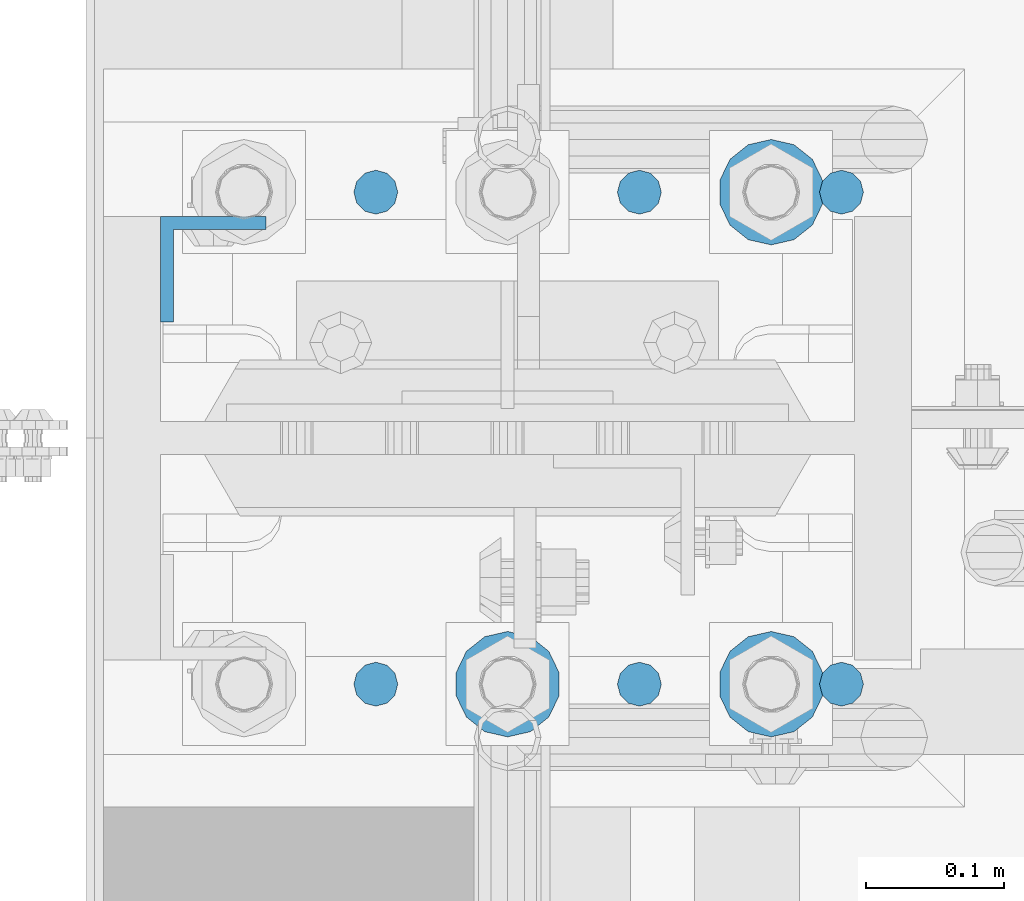
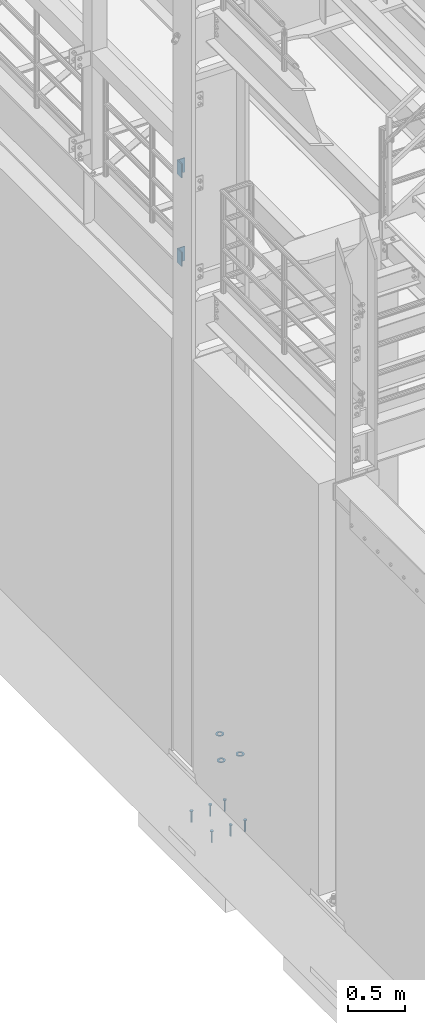
# One storey, part 816 of 1876: 11 columns, 2 elements without a shape of their own.
"""IFC2X3 building model written with IfcOpenShell, lengths in millimetres."""

from ifc_helpers import new_model, si_unit, frame, origin_with_axes, place, context, subcontext, project, spatial, faceted_brep, material, type_object, element, aggregate, save


model = new_model("IFC2X3")

# Units and contexts
model_context = context("Model", 3, precision=1e-05, world=origin_with_axes())
body_context = subcontext(model_context, "Body", "Model", "MODEL_VIEW")
ifc_project = project(units=[si_unit("LENGTHUNIT", "METRE", prefix="MILLI"), si_unit("AREAUNIT", "SQUARE_METRE"), si_unit("VOLUMEUNIT", "CUBIC_METRE"), si_unit("MASSUNIT", "GRAM", prefix="KILO"), si_unit("TIMEUNIT", "SECOND"), si_unit("PLANEANGLEUNIT", "RADIAN"), si_unit("SOLIDANGLEUNIT", "STERADIAN"), si_unit("THERMODYNAMICTEMPERATUREUNIT", "DEGREE_CELSIUS"), si_unit("LUMINOUSINTENSITYUNIT", "LUMEN")], contexts=[model_context])

# Site, building, storey
site_placement = place(None, origin_with_axes())
site = spatial("IfcSite", under=ifc_project, at=site_placement, CompositionType="ELEMENT")
building_placement = place(site_placement, origin_with_axes())
building = spatial("IfcBuilding", under=site, at=building_placement, Name="Undefined", CompositionType="ELEMENT")
storey_placement = place(building_placement, origin_with_axes())
storey = spatial("IfcBuildingStorey", under=building, at=storey_placement, Name="Undefined", CompositionType="ELEMENT", Elevation=0.0)

# Assembly, columns
assembly_1_placement = place(storey_placement, origin_with_axes())
assembly_1 = element("IfcElementAssembly", 1, at=assembly_1_placement, inside=storey, Name="COLUMN", AssemblyPlace="NOTDEFINED", PredefinedType="RIGID_FRAME")
ifc_material_1 = material(Name="STEEL/A36")
column_type_1 = type_object("IfcColumnType", Name="L3X3X3/8", PredefinedType="NOTDEFINED")
column_1_placement = place(assembly_1_placement, frame((-212.725, -4449.7625, 6254.75), z_axis=(0.0, -1.0, 0.0), x_axis=(0.0, 0.0, 1.0)))
column_1 = element("IfcColumn", 2, at=column_1_placement, type_object=column_type_1, material=ifc_material_1, Name="ANGLE", ObjectType="L3X3X3/8", context=body_context, shape_type="Brep", body=[
    faceted_brep([(0.0, 38.1000000000004, -38.1), (0.0, 38.1000000000004, 38.1), (152.4, 38.1000000000004, 38.1), (152.4, 38.1000000000004, -38.1), (0.0, 28.5749999999998, 38.1), (152.4, 28.5749999999998, 38.1), (0.0, 28.5749999999998, -28.575), (152.4, 28.5749999999998, -28.575), (0.0, -38.1000000000004, -28.575), (152.4, -38.1000000000004, -28.575), (0.0, -38.1000000000004, -38.1), (152.4, -38.1000000000004, -38.1)], [[[0, 1, 2, 3]], [[1, 4, 5, 2]], [[4, 6, 7, 5]], [[6, 8, 9, 7]], [[8, 10, 11, 9]], [[10, 0, 3, 11]], [[5, 7, 9, 11, 3, 2]], [[10, 8, 6, 4, 1, 0]]]),
])
column_2_placement = place(assembly_1_placement, frame((-212.725, -4449.7625, 5308.6), z_axis=(0.0, -1.0, 0.0), x_axis=(0.0, 0.0, 1.0)))
column_2 = element("IfcColumn", 3, at=column_2_placement, type_object=column_type_1, material=ifc_material_1, Name="ANGLE", ObjectType="L3X3X3/8", context=body_context, shape_type="Brep", body=[
    faceted_brep([(0.0, 38.1000000000004, -38.1), (0.0, 38.1000000000004, 38.1), (152.4, 38.1000000000004, 38.1), (152.4, 38.1000000000004, -38.1), (0.0, 28.5749999999998, 38.1), (152.4, 28.5749999999998, 38.1), (0.0, 28.5749999999998, -28.575), (152.4, 28.5749999999998, -28.575), (0.0, -38.1000000000004, -28.575), (152.4, -38.1000000000004, -28.575), (0.0, -38.1000000000004, -38.1), (152.4, -38.1000000000004, -38.1)], [[[0, 1, 2, 3]], [[1, 4, 5, 2]], [[4, 6, 7, 5]], [[6, 8, 9, 7]], [[8, 10, 11, 9]], [[10, 0, 3, 11]], [[5, 7, 9, 11, 3, 2]], [[10, 8, 6, 4, 1, 0]]]),
])
aggregate(assembly_1, [column_1, column_2])

assembly_2_placement = place(storey_placement, origin_with_axes())
assembly_2 = element("IfcElementAssembly", 4, at=assembly_2_placement, inside=storey, Name="TEMPLATE", AssemblyPlace="NOTDEFINED", PredefinedType="RIGID_FRAME")
ifc_material_2 = material(Name="STEEL/F436")
column_type_2 = type_object("IfcColumnType", Name="1-1/2_WASHER", PredefinedType="NOTDEFINED")
column_3_placement = place(assembly_2_placement, frame((190.5, -4749.8, 109.5375), z_axis=(1.0, 0.0, 0.0), x_axis=(0.0, 0.0, -1.0)))
column_3 = element("IfcColumn", 5, at=column_3_placement, type_object=column_type_2, material=ifc_material_2, Name="WASHER", ObjectType="1-1/2_WASHER", context=body_context, shape_type="Brep", body=[
    faceted_brep([(0.0, -38.0999984741211, 0.0), (0.0, -34.3269124923136, -16.5309697983251), (4.7625, -34.3269124923136, -16.5309697983251), (4.7625, -38.0999984741211, 0.0), (0.0, -23.7549604994474, -29.787778289052), (4.7625, -23.7549604994474, -29.787778289052), (0.0, -8.4780472441962, -37.1447519665058), (4.7625, -8.4780472441962, -37.1447519665058), (0.0, 8.4780472441962, -37.1447519665058), (4.7625, 8.4780472441962, -37.1447519665058), (0.0, 23.7549604994474, -29.787778289052), (4.7625, 23.7549604994474, -29.787778289052), (0.0, 34.3269124923136, -16.5309697983251), (4.7625, 34.3269124923136, -16.5309697983251), (0.0, 38.0999984741211, 0.0), (4.7625, 38.0999984741211, 0.0), (0.0, 34.3269124923136, 16.5309697983251), (4.7625, 34.3269124923136, 16.5309697983251), (0.0, 23.7549604994474, 29.787778289052), (4.7625, 23.7549604994474, 29.787778289052), (0.0, 8.4780472441962, 37.1447519665058), (4.7625, 8.4780472441962, 37.1447519665058), (0.0, -8.4780472441962, 37.1447519665058), (4.7625, -8.4780472441962, 37.1447519665058), (0.0, -23.7549604994474, 29.787778289052), (4.7625, -23.7549604994474, 29.787778289052), (0.0, -34.3269124923136, 16.5309697983251), (4.7625, -34.3269124923136, 16.5309697983251), (0.0, 0.0, 20.6399993896484), (0.0, 8.95536011056538, 18.5959968835978), (4.7625, 8.95536011056538, 18.595996883598), (4.7625, 0.0, 20.6399993896484), (0.0, 16.1370013209489, 12.8688291298158), (4.7625, 16.1370013209489, 12.8688291298162), (0.0, 20.1225115123834, 4.59283194104228), (4.7625, 20.1225115123834, 4.59283194104222), (0.0, 20.1225115123834, -4.59283194104228), (4.7625, 20.1225115123834, -4.59283194104242), (0.0, 16.1370013209489, -12.8688291298167), (4.7625, 16.1370013209489, -12.8688291298163), (0.0, 8.95536011056538, -18.5959968835978), (4.7625, 8.95536011056538, -18.5959968835982), (0.0, 0.0, -20.6399993896484), (4.7625, 0.0, -20.6399993896484), (0.0, -8.95536011056538, -18.5959968835978), (4.7625, -8.95536011056538, -18.595996883598), (0.0, -16.1370013209489, -12.8688291298158), (4.7625, -16.1370013209489, -12.8688291298162), (0.0, -20.1225115123834, -4.59283194104228), (4.7625, -20.1225115123834, -4.59283194104222), (0.0, -20.1225115123834, 4.59283194104228), (4.7625, -20.1225115123834, 4.59283194104242), (0.0, -16.1370013209489, 12.8688291298167), (4.7625, -16.1370013209489, 12.8688291298163), (0.0, -8.95536011056538, 18.5959968835978), (4.7625, -8.95536011056538, 18.5959968835982)], [[[0, 1, 2, 3]], [[1, 4, 5, 2]], [[4, 6, 7, 5]], [[6, 8, 9, 7]], [[8, 10, 11, 9]], [[10, 12, 13, 11]], [[12, 14, 15, 13]], [[14, 16, 17, 15]], [[16, 18, 19, 17]], [[18, 20, 21, 19]], [[20, 22, 23, 21]], [[22, 24, 25, 23]], [[24, 26, 27, 25]], [[26, 0, 3, 27]], [[28, 29, 30, 31]], [[29, 32, 33, 30]], [[32, 34, 35, 33]], [[34, 36, 37, 35]], [[36, 38, 39, 37]], [[38, 40, 41, 39]], [[40, 42, 43, 41]], [[42, 44, 45, 43]], [[44, 46, 47, 45]], [[46, 48, 49, 47]], [[48, 50, 51, 49]], [[50, 52, 53, 51]], [[52, 54, 55, 53]], [[54, 28, 31, 55]], [[5, 7, 9, 11, 13, 15, 17, 19, 21, 23, 25, 27, 3, 2], [33, 35, 37, 39, 41, 43, 45, 47, 49, 51, 53, 55, 31, 30]], [[26, 24, 22, 20, 18, 16, 14, 12, 10, 8, 6, 4, 1, 0], [54, 52, 50, 48, 46, 44, 42, 40, 38, 36, 34, 32, 29, 28]]]),
])
column_4_placement = place(assembly_2_placement, frame((190.5, -4394.2, 109.5375), z_axis=(-1.0, 0.0, 0.0), x_axis=(0.0, 0.0, -1.0)))
column_4 = element("IfcColumn", 6, at=column_4_placement, type_object=column_type_2, material=ifc_material_2, Name="WASHER", ObjectType="1-1/2_WASHER", context=body_context, shape_type="Brep", body=[
    faceted_brep([(0.0, -38.0999984741211, 0.0), (0.0, -34.3269124923136, -16.5309697983251), (4.7625, -34.3269124923136, -16.5309697983251), (4.7625, -38.0999984741211, 0.0), (0.0, -23.7549604994474, -29.787778289052), (4.7625, -23.7549604994474, -29.787778289052), (0.0, -8.4780472441962, -37.1447519665058), (4.7625, -8.4780472441962, -37.1447519665058), (0.0, 8.4780472441962, -37.1447519665058), (4.7625, 8.4780472441962, -37.1447519665058), (0.0, 23.7549604994474, -29.787778289052), (4.7625, 23.7549604994474, -29.787778289052), (0.0, 34.3269124923136, -16.5309697983251), (4.7625, 34.3269124923136, -16.5309697983251), (0.0, 38.0999984741211, 0.0), (4.7625, 38.0999984741211, 0.0), (0.0, 34.3269124923136, 16.5309697983251), (4.7625, 34.3269124923136, 16.5309697983251), (0.0, 23.7549604994474, 29.787778289052), (4.7625, 23.7549604994474, 29.787778289052), (0.0, 8.4780472441962, 37.1447519665058), (4.7625, 8.4780472441962, 37.1447519665058), (0.0, -8.4780472441962, 37.1447519665058), (4.7625, -8.4780472441962, 37.1447519665058), (0.0, -23.7549604994474, 29.787778289052), (4.7625, -23.7549604994474, 29.787778289052), (0.0, -34.3269124923136, 16.5309697983251), (4.7625, -34.3269124923136, 16.5309697983251), (0.0, 0.0, 20.6399993896484), (0.0, 8.95536011056538, 18.5959968835978), (4.7625, 8.95536011056538, 18.595996883598), (4.7625, 0.0, 20.6399993896484), (0.0, 16.1370013209489, 12.8688291298158), (4.7625, 16.1370013209489, 12.8688291298162), (0.0, 20.1225115123834, 4.59283194104228), (4.7625, 20.1225115123834, 4.59283194104222), (0.0, 20.1225115123834, -4.59283194104228), (4.7625, 20.1225115123834, -4.59283194104242), (0.0, 16.1370013209489, -12.8688291298167), (4.7625, 16.1370013209489, -12.8688291298163), (0.0, 8.95536011056538, -18.5959968835978), (4.7625, 8.95536011056538, -18.5959968835982), (0.0, 0.0, -20.6399993896484), (4.7625, 0.0, -20.6399993896484), (0.0, -8.95536011056538, -18.5959968835978), (4.7625, -8.95536011056538, -18.595996883598), (0.0, -16.1370013209489, -12.8688291298158), (4.7625, -16.1370013209489, -12.8688291298162), (0.0, -20.1225115123834, -4.59283194104228), (4.7625, -20.1225115123834, -4.59283194104222), (0.0, -20.1225115123834, 4.59283194104228), (4.7625, -20.1225115123834, 4.59283194104242), (0.0, -16.1370013209489, 12.8688291298167), (4.7625, -16.1370013209489, 12.8688291298163), (0.0, -8.95536011056538, 18.5959968835978), (4.7625, -8.95536011056538, 18.5959968835982)], [[[0, 1, 2, 3]], [[1, 4, 5, 2]], [[4, 6, 7, 5]], [[6, 8, 9, 7]], [[8, 10, 11, 9]], [[10, 12, 13, 11]], [[12, 14, 15, 13]], [[14, 16, 17, 15]], [[16, 18, 19, 17]], [[18, 20, 21, 19]], [[20, 22, 23, 21]], [[22, 24, 25, 23]], [[24, 26, 27, 25]], [[26, 0, 3, 27]], [[28, 29, 30, 31]], [[29, 32, 33, 30]], [[32, 34, 35, 33]], [[34, 36, 37, 35]], [[36, 38, 39, 37]], [[38, 40, 41, 39]], [[40, 42, 43, 41]], [[42, 44, 45, 43]], [[44, 46, 47, 45]], [[46, 48, 49, 47]], [[48, 50, 51, 49]], [[50, 52, 53, 51]], [[52, 54, 55, 53]], [[54, 28, 31, 55]], [[5, 7, 9, 11, 13, 15, 17, 19, 21, 23, 25, 27, 3, 2], [33, 35, 37, 39, 41, 43, 45, 47, 49, 51, 53, 55, 31, 30]], [[26, 24, 22, 20, 18, 16, 14, 12, 10, 8, 6, 4, 1, 0], [54, 52, 50, 48, 46, 44, 42, 40, 38, 36, 34, 32, 29, 28]]]),
])
column_5_placement = place(assembly_2_placement, frame((-2.8421709430404e-14, -4749.8, 109.5375), z_axis=(1.0, 0.0, 0.0), x_axis=(0.0, 0.0, -1.0)))
column_5 = element("IfcColumn", 7, at=column_5_placement, type_object=column_type_2, material=ifc_material_2, Name="WASHER", ObjectType="1-1/2_WASHER", context=body_context, shape_type="Brep", body=[
    faceted_brep([(0.0, -38.0999984741211, 0.0), (0.0, -34.3269124923136, -16.5309697983251), (4.7625, -34.3269124923136, -16.5309697983251), (4.7625, -38.0999984741211, 0.0), (0.0, -23.7549604994474, -29.787778289052), (4.7625, -23.7549604994474, -29.787778289052), (0.0, -8.4780472441962, -37.1447519665058), (4.7625, -8.4780472441962, -37.1447519665058), (0.0, 8.4780472441962, -37.1447519665058), (4.7625, 8.4780472441962, -37.1447519665058), (0.0, 23.7549604994474, -29.787778289052), (4.7625, 23.7549604994474, -29.787778289052), (0.0, 34.3269124923136, -16.5309697983251), (4.7625, 34.3269124923136, -16.5309697983251), (0.0, 38.0999984741211, 0.0), (4.7625, 38.0999984741211, 0.0), (0.0, 34.3269124923136, 16.5309697983251), (4.7625, 34.3269124923136, 16.5309697983251), (0.0, 23.7549604994474, 29.787778289052), (4.7625, 23.7549604994474, 29.787778289052), (0.0, 8.4780472441962, 37.1447519665058), (4.7625, 8.4780472441962, 37.1447519665058), (0.0, -8.4780472441962, 37.1447519665058), (4.7625, -8.4780472441962, 37.1447519665058), (0.0, -23.7549604994474, 29.787778289052), (4.7625, -23.7549604994474, 29.787778289052), (0.0, -34.3269124923136, 16.5309697983251), (4.7625, -34.3269124923136, 16.5309697983251), (0.0, 0.0, 20.6399993896484), (0.0, 8.95536011056538, 18.5959968835978), (4.7625, 8.95536011056538, 18.595996883598), (4.7625, 0.0, 20.6399993896484), (0.0, 16.1370013209489, 12.8688291298158), (4.7625, 16.1370013209489, 12.8688291298162), (0.0, 20.1225115123834, 4.59283194104228), (4.7625, 20.1225115123834, 4.59283194104222), (0.0, 20.1225115123834, -4.59283194104228), (4.7625, 20.1225115123834, -4.59283194104242), (0.0, 16.1370013209489, -12.8688291298167), (4.7625, 16.1370013209489, -12.8688291298163), (0.0, 8.95536011056538, -18.5959968835978), (4.7625, 8.95536011056538, -18.5959968835982), (0.0, 0.0, -20.6399993896484), (4.7625, 0.0, -20.6399993896484), (0.0, -8.95536011056538, -18.5959968835978), (4.7625, -8.95536011056538, -18.595996883598), (0.0, -16.1370013209489, -12.8688291298158), (4.7625, -16.1370013209489, -12.8688291298162), (0.0, -20.1225115123834, -4.59283194104228), (4.7625, -20.1225115123834, -4.59283194104222), (0.0, -20.1225115123834, 4.59283194104228), (4.7625, -20.1225115123834, 4.59283194104242), (0.0, -16.1370013209489, 12.8688291298167), (4.7625, -16.1370013209489, 12.8688291298163), (0.0, -8.95536011056538, 18.5959968835978), (4.7625, -8.95536011056538, 18.5959968835982)], [[[0, 1, 2, 3]], [[1, 4, 5, 2]], [[4, 6, 7, 5]], [[6, 8, 9, 7]], [[8, 10, 11, 9]], [[10, 12, 13, 11]], [[12, 14, 15, 13]], [[14, 16, 17, 15]], [[16, 18, 19, 17]], [[18, 20, 21, 19]], [[20, 22, 23, 21]], [[22, 24, 25, 23]], [[24, 26, 27, 25]], [[26, 0, 3, 27]], [[28, 29, 30, 31]], [[29, 32, 33, 30]], [[32, 34, 35, 33]], [[34, 36, 37, 35]], [[36, 38, 39, 37]], [[38, 40, 41, 39]], [[40, 42, 43, 41]], [[42, 44, 45, 43]], [[44, 46, 47, 45]], [[46, 48, 49, 47]], [[48, 50, 51, 49]], [[50, 52, 53, 51]], [[52, 54, 55, 53]], [[54, 28, 31, 55]], [[5, 7, 9, 11, 13, 15, 17, 19, 21, 23, 25, 27, 3, 2], [33, 35, 37, 39, 41, 43, 45, 47, 49, 51, 53, 55, 31, 30]], [[26, 24, 22, 20, 18, 16, 14, 12, 10, 8, 6, 4, 1, 0], [54, 52, 50, 48, 46, 44, 42, 40, 38, 36, 34, 32, 29, 28]]]),
])
ifc_material_3 = material(Name="STEEL/A108")
column_type_3 = type_object("IfcColumnType", Name="5/8-DIA_HEADED ANCHOR STUD", PredefinedType="NOTDEFINED")
column_6_placement = place(assembly_2_placement, frame((241.299998474122, -4394.2, -736.6), z_axis=(1.0, 0.0, 0.0), x_axis=(0.0, 0.0, 1.0)))
column_6 = element("IfcColumn", 8, at=column_6_placement, type_object=column_type_3, material=ifc_material_3, Name="HEADED ANCHOR STUD", ObjectType="5/8-DIA_HEADED ANCHOR STUD", context=body_context, shape_type="Brep", body=[
    faceted_brep([(0.0, -7.94000005722046, 0.0), (0.0, -6.86999988555908, -3.97000002861023), (116.84, -6.86999988555908, -3.97000002861023), (116.84, -7.94000005722046, 0.0), (0.0, -3.97000002861023, -6.86999988555908), (116.84, -3.97000002861023, -6.86999988555908), (0.0, 0.0, -7.94000005722046), (116.84, 0.0, -7.94000005722046), (0.0, 3.97000002861023, -6.86999988555908), (116.84, 3.97000002861023, -6.86999988555908), (0.0, 6.86999988555908, -3.97000002861023), (116.84, 6.86999988555908, -3.97000002861023), (0.0, 7.94000005722046, 0.0), (116.84, 7.94000005722046, 0.0), (0.0, 6.86999988555908, 3.97000002861023), (116.84, 6.86999988555908, 3.97000002861023), (0.0, 3.97000002861023, 6.86999988555908), (116.84, 3.97000002861023, 6.86999988555908), (0.0, 0.0, 7.94000005722046), (116.84, 0.0, 7.94000005722046), (0.0, -3.97000002861023, 6.86999988555908), (116.84, -3.97000002861023, 6.86999988555908), (0.0, -6.86999988555908, 3.97000002861023), (116.84, -6.86999988555908, 3.97000002861023), (118.11, -13.75, -7.94000005722046), (118.11, -15.8800001144409, 0.0), (118.11, -7.94000005722046, -13.75), (118.11, 0.0, -15.8800001144409), (118.11, 7.94000005722046, -13.75), (118.11, 13.75, -7.94000005722046), (118.11, 15.8800001144409, 0.0), (118.11, 13.75, 7.94000005722046), (118.11, 7.94000005722046, 13.75), (118.11, 0.0, 15.8800001144409), (118.11, -7.94000005722046, 13.75), (118.11, -13.75, 7.94000005722046), (127.0, -13.75, -7.94000005722046), (127.0, -15.8800001144409, 0.0), (127.0, -7.94000005722046, -13.75), (127.0, 0.0, -15.8800001144409), (127.0, 7.94000005722046, -13.75), (127.0, 13.75, -7.94000005722046), (127.0, 15.8800001144409, 0.0), (127.0, 13.75, 7.94000005722046), (127.0, 7.94000005722046, 13.75), (127.0, 0.0, 15.8800001144409), (127.0, -7.94000005722046, 13.75), (127.0, -13.75, 7.94000005722046)], [[[0, 1, 2, 3]], [[1, 4, 5, 2]], [[4, 6, 7, 5]], [[6, 8, 9, 7]], [[8, 10, 11, 9]], [[10, 12, 13, 11]], [[12, 14, 15, 13]], [[14, 16, 17, 15]], [[16, 18, 19, 17]], [[18, 20, 21, 19]], [[20, 22, 23, 21]], [[22, 0, 3, 23]], [[22, 20, 18, 16, 14, 12, 10, 8, 6, 4, 1, 0]], [[3, 2, 24, 25]], [[2, 5, 26, 24]], [[5, 7, 27, 26]], [[7, 9, 28, 27]], [[9, 11, 29, 28]], [[11, 13, 30, 29]], [[13, 15, 31, 30]], [[15, 17, 32, 31]], [[17, 19, 33, 32]], [[19, 21, 34, 33]], [[21, 23, 35, 34]], [[23, 3, 25, 35]], [[25, 24, 36, 37]], [[24, 26, 38, 36]], [[26, 27, 39, 38]], [[27, 28, 40, 39]], [[28, 29, 41, 40]], [[29, 30, 42, 41]], [[30, 31, 43, 42]], [[31, 32, 44, 43]], [[32, 33, 45, 44]], [[33, 34, 46, 45]], [[34, 35, 47, 46]], [[35, 25, 37, 47]], [[38, 39, 40, 41, 42, 43, 44, 45, 46, 47, 37, 36]]]),
])
column_7_placement = place(assembly_2_placement, frame((241.299998474122, -4749.8, -736.6), z_axis=(1.0, 0.0, 0.0), x_axis=(0.0, 0.0, 1.0)))
column_7 = element("IfcColumn", 9, at=column_7_placement, type_object=column_type_3, material=ifc_material_3, Name="HEADED ANCHOR STUD", ObjectType="5/8-DIA_HEADED ANCHOR STUD", context=body_context, shape_type="Brep", body=[
    faceted_brep([(0.0, -7.94000005722046, 0.0), (0.0, -6.86999988555908, -3.97000002861023), (116.84, -6.86999988555908, -3.97000002861023), (116.84, -7.94000005722046, 0.0), (0.0, -3.97000002861023, -6.86999988555908), (116.84, -3.97000002861023, -6.86999988555908), (0.0, 0.0, -7.94000005722046), (116.84, 0.0, -7.94000005722046), (0.0, 3.97000002861023, -6.86999988555908), (116.84, 3.97000002861023, -6.86999988555908), (0.0, 6.86999988555908, -3.97000002861023), (116.84, 6.86999988555908, -3.97000002861023), (0.0, 7.94000005722046, 0.0), (116.84, 7.94000005722046, 0.0), (0.0, 6.86999988555908, 3.97000002861023), (116.84, 6.86999988555908, 3.97000002861023), (0.0, 3.97000002861023, 6.86999988555908), (116.84, 3.97000002861023, 6.86999988555908), (0.0, 0.0, 7.94000005722046), (116.84, 0.0, 7.94000005722046), (0.0, -3.97000002861023, 6.86999988555908), (116.84, -3.97000002861023, 6.86999988555908), (0.0, -6.86999988555908, 3.97000002861023), (116.84, -6.86999988555908, 3.97000002861023), (118.11, -13.75, -7.94000005722046), (118.11, -15.8800001144409, 0.0), (118.11, -7.94000005722046, -13.75), (118.11, 0.0, -15.8800001144409), (118.11, 7.94000005722046, -13.75), (118.11, 13.75, -7.94000005722046), (118.11, 15.8800001144409, 0.0), (118.11, 13.75, 7.94000005722046), (118.11, 7.94000005722046, 13.75), (118.11, 0.0, 15.8800001144409), (118.11, -7.94000005722046, 13.75), (118.11, -13.75, 7.94000005722046), (127.0, -13.75, -7.94000005722046), (127.0, -15.8800001144409, 0.0), (127.0, -7.94000005722046, -13.75), (127.0, 0.0, -15.8800001144409), (127.0, 7.94000005722046, -13.75), (127.0, 13.75, -7.94000005722046), (127.0, 15.8800001144409, 0.0), (127.0, 13.75, 7.94000005722046), (127.0, 7.94000005722046, 13.75), (127.0, 0.0, 15.8800001144409), (127.0, -7.94000005722046, 13.75), (127.0, -13.75, 7.94000005722046)], [[[0, 1, 2, 3]], [[1, 4, 5, 2]], [[4, 6, 7, 5]], [[6, 8, 9, 7]], [[8, 10, 11, 9]], [[10, 12, 13, 11]], [[12, 14, 15, 13]], [[14, 16, 17, 15]], [[16, 18, 19, 17]], [[18, 20, 21, 19]], [[20, 22, 23, 21]], [[22, 0, 3, 23]], [[22, 20, 18, 16, 14, 12, 10, 8, 6, 4, 1, 0]], [[3, 2, 24, 25]], [[2, 5, 26, 24]], [[5, 7, 27, 26]], [[7, 9, 28, 27]], [[9, 11, 29, 28]], [[11, 13, 30, 29]], [[13, 15, 31, 30]], [[15, 17, 32, 31]], [[17, 19, 33, 32]], [[19, 21, 34, 33]], [[21, 23, 35, 34]], [[23, 3, 25, 35]], [[25, 24, 36, 37]], [[24, 26, 38, 36]], [[26, 27, 39, 38]], [[27, 28, 40, 39]], [[28, 29, 41, 40]], [[29, 30, 42, 41]], [[30, 31, 43, 42]], [[31, 32, 44, 43]], [[32, 33, 45, 44]], [[33, 34, 46, 45]], [[34, 35, 47, 46]], [[35, 25, 37, 47]], [[38, 39, 40, 41, 42, 43, 44, 45, 46, 47, 37, 36]]]),
])
column_8_placement = place(assembly_2_placement, frame((-95.2500000000003, -4394.2, -736.6), z_axis=(1.0, 0.0, 0.0), x_axis=(0.0, 0.0, 1.0)))
column_8 = element("IfcColumn", 10, at=column_8_placement, type_object=column_type_3, material=ifc_material_3, Name="HEADED ANCHOR STUD", ObjectType="5/8-DIA_HEADED ANCHOR STUD", context=body_context, shape_type="Brep", body=[
    faceted_brep([(0.0, -7.94000005722046, 0.0), (0.0, -6.86999988555908, -3.97000002861023), (116.84, -6.86999988555908, -3.97000002861023), (116.84, -7.94000005722046, 0.0), (0.0, -3.97000002861023, -6.86999988555908), (116.84, -3.97000002861023, -6.86999988555908), (0.0, 0.0, -7.94000005722046), (116.84, 0.0, -7.94000005722046), (0.0, 3.97000002861023, -6.86999988555908), (116.84, 3.97000002861023, -6.86999988555908), (0.0, 6.86999988555908, -3.97000002861023), (116.84, 6.86999988555908, -3.97000002861023), (0.0, 7.94000005722046, 0.0), (116.84, 7.94000005722046, 0.0), (0.0, 6.86999988555908, 3.97000002861023), (116.84, 6.86999988555908, 3.97000002861023), (0.0, 3.97000002861023, 6.86999988555908), (116.84, 3.97000002861023, 6.86999988555908), (0.0, 0.0, 7.94000005722046), (116.84, 0.0, 7.94000005722046), (0.0, -3.97000002861023, 6.86999988555908), (116.84, -3.97000002861023, 6.86999988555908), (0.0, -6.86999988555908, 3.97000002861023), (116.84, -6.86999988555908, 3.97000002861023), (118.11, -13.75, -7.94000005722046), (118.11, -15.8800001144409, 0.0), (118.11, -7.94000005722046, -13.75), (118.11, 0.0, -15.8800001144409), (118.11, 7.94000005722046, -13.75), (118.11, 13.75, -7.94000005722046), (118.11, 15.8800001144409, 0.0), (118.11, 13.75, 7.94000005722046), (118.11, 7.94000005722046, 13.75), (118.11, 0.0, 15.8800001144409), (118.11, -7.94000005722046, 13.75), (118.11, -13.75, 7.94000005722046), (127.0, -13.75, -7.94000005722046), (127.0, -15.8800001144409, 0.0), (127.0, -7.94000005722046, -13.75), (127.0, 0.0, -15.8800001144409), (127.0, 7.94000005722046, -13.75), (127.0, 13.75, -7.94000005722046), (127.0, 15.8800001144409, 0.0), (127.0, 13.75, 7.94000005722046), (127.0, 7.94000005722046, 13.75), (127.0, 0.0, 15.8800001144409), (127.0, -7.94000005722046, 13.75), (127.0, -13.75, 7.94000005722046)], [[[0, 1, 2, 3]], [[1, 4, 5, 2]], [[4, 6, 7, 5]], [[6, 8, 9, 7]], [[8, 10, 11, 9]], [[10, 12, 13, 11]], [[12, 14, 15, 13]], [[14, 16, 17, 15]], [[16, 18, 19, 17]], [[18, 20, 21, 19]], [[20, 22, 23, 21]], [[22, 0, 3, 23]], [[22, 20, 18, 16, 14, 12, 10, 8, 6, 4, 1, 0]], [[3, 2, 24, 25]], [[2, 5, 26, 24]], [[5, 7, 27, 26]], [[7, 9, 28, 27]], [[9, 11, 29, 28]], [[11, 13, 30, 29]], [[13, 15, 31, 30]], [[15, 17, 32, 31]], [[17, 19, 33, 32]], [[19, 21, 34, 33]], [[21, 23, 35, 34]], [[23, 3, 25, 35]], [[25, 24, 36, 37]], [[24, 26, 38, 36]], [[26, 27, 39, 38]], [[27, 28, 40, 39]], [[28, 29, 41, 40]], [[29, 30, 42, 41]], [[30, 31, 43, 42]], [[31, 32, 44, 43]], [[32, 33, 45, 44]], [[33, 34, 46, 45]], [[34, 35, 47, 46]], [[35, 25, 37, 47]], [[38, 39, 40, 41, 42, 43, 44, 45, 46, 47, 37, 36]]]),
])
column_9_placement = place(assembly_2_placement, frame((-95.2500000000003, -4749.8, -736.6), z_axis=(1.0, 0.0, 0.0), x_axis=(0.0, 0.0, 1.0)))
column_9 = element("IfcColumn", 11, at=column_9_placement, type_object=column_type_3, material=ifc_material_3, Name="HEADED ANCHOR STUD", ObjectType="5/8-DIA_HEADED ANCHOR STUD", context=body_context, shape_type="Brep", body=[
    faceted_brep([(0.0, -7.94000005722046, 0.0), (0.0, -6.86999988555908, -3.97000002861023), (116.84, -6.86999988555908, -3.97000002861023), (116.84, -7.94000005722046, 0.0), (0.0, -3.97000002861023, -6.86999988555908), (116.84, -3.97000002861023, -6.86999988555908), (0.0, 0.0, -7.94000005722046), (116.84, 0.0, -7.94000005722046), (0.0, 3.97000002861023, -6.86999988555908), (116.84, 3.97000002861023, -6.86999988555908), (0.0, 6.86999988555908, -3.97000002861023), (116.84, 6.86999988555908, -3.97000002861023), (0.0, 7.94000005722046, 0.0), (116.84, 7.94000005722046, 0.0), (0.0, 6.86999988555908, 3.97000002861023), (116.84, 6.86999988555908, 3.97000002861023), (0.0, 3.97000002861023, 6.86999988555908), (116.84, 3.97000002861023, 6.86999988555908), (0.0, 0.0, 7.94000005722046), (116.84, 0.0, 7.94000005722046), (0.0, -3.97000002861023, 6.86999988555908), (116.84, -3.97000002861023, 6.86999988555908), (0.0, -6.86999988555908, 3.97000002861023), (116.84, -6.86999988555908, 3.97000002861023), (118.11, -13.75, -7.94000005722046), (118.11, -15.8800001144409, 0.0), (118.11, -7.94000005722046, -13.75), (118.11, 0.0, -15.8800001144409), (118.11, 7.94000005722046, -13.75), (118.11, 13.75, -7.94000005722046), (118.11, 15.8800001144409, 0.0), (118.11, 13.75, 7.94000005722046), (118.11, 7.94000005722046, 13.75), (118.11, 0.0, 15.8800001144409), (118.11, -7.94000005722046, 13.75), (118.11, -13.75, 7.94000005722046), (127.0, -13.75, -7.94000005722046), (127.0, -15.8800001144409, 0.0), (127.0, -7.94000005722046, -13.75), (127.0, 0.0, -15.8800001144409), (127.0, 7.94000005722046, -13.75), (127.0, 13.75, -7.94000005722046), (127.0, 15.8800001144409, 0.0), (127.0, 13.75, 7.94000005722046), (127.0, 7.94000005722046, 13.75), (127.0, 0.0, 15.8800001144409), (127.0, -7.94000005722046, 13.75), (127.0, -13.75, 7.94000005722046)], [[[0, 1, 2, 3]], [[1, 4, 5, 2]], [[4, 6, 7, 5]], [[6, 8, 9, 7]], [[8, 10, 11, 9]], [[10, 12, 13, 11]], [[12, 14, 15, 13]], [[14, 16, 17, 15]], [[16, 18, 19, 17]], [[18, 20, 21, 19]], [[20, 22, 23, 21]], [[22, 0, 3, 23]], [[22, 20, 18, 16, 14, 12, 10, 8, 6, 4, 1, 0]], [[3, 2, 24, 25]], [[2, 5, 26, 24]], [[5, 7, 27, 26]], [[7, 9, 28, 27]], [[9, 11, 29, 28]], [[11, 13, 30, 29]], [[13, 15, 31, 30]], [[15, 17, 32, 31]], [[17, 19, 33, 32]], [[19, 21, 34, 33]], [[21, 23, 35, 34]], [[23, 3, 25, 35]], [[25, 24, 36, 37]], [[24, 26, 38, 36]], [[26, 27, 39, 38]], [[27, 28, 40, 39]], [[28, 29, 41, 40]], [[29, 30, 42, 41]], [[30, 31, 43, 42]], [[31, 32, 44, 43]], [[32, 33, 45, 44]], [[33, 34, 46, 45]], [[34, 35, 47, 46]], [[35, 25, 37, 47]], [[38, 39, 40, 41, 42, 43, 44, 45, 46, 47, 37, 36]]]),
])
column_10_placement = place(assembly_2_placement, frame((95.2500000000006, -4394.2, -736.6), z_axis=(1.0, 0.0, 0.0), x_axis=(0.0, 0.0, 1.0)))
column_10 = element("IfcColumn", 12, at=column_10_placement, type_object=column_type_3, material=ifc_material_3, Name="HEADED ANCHOR STUD", ObjectType="5/8-DIA_HEADED ANCHOR STUD", context=body_context, shape_type="Brep", body=[
    faceted_brep([(0.0, -7.94000005722046, 0.0), (0.0, -6.86999988555908, -3.97000002861023), (116.84, -6.86999988555908, -3.97000002861023), (116.84, -7.94000005722046, 0.0), (0.0, -3.97000002861023, -6.86999988555908), (116.84, -3.97000002861023, -6.86999988555908), (0.0, 0.0, -7.94000005722046), (116.84, 0.0, -7.94000005722046), (0.0, 3.97000002861023, -6.86999988555908), (116.84, 3.97000002861023, -6.86999988555908), (0.0, 6.86999988555908, -3.97000002861023), (116.84, 6.86999988555908, -3.97000002861023), (0.0, 7.94000005722046, 0.0), (116.84, 7.94000005722046, 0.0), (0.0, 6.86999988555908, 3.97000002861023), (116.84, 6.86999988555908, 3.97000002861023), (0.0, 3.97000002861023, 6.86999988555908), (116.84, 3.97000002861023, 6.86999988555908), (0.0, 0.0, 7.94000005722046), (116.84, 0.0, 7.94000005722046), (0.0, -3.97000002861023, 6.86999988555908), (116.84, -3.97000002861023, 6.86999988555908), (0.0, -6.86999988555908, 3.97000002861023), (116.84, -6.86999988555908, 3.97000002861023), (118.11, -13.75, -7.94000005722046), (118.11, -15.8800001144409, 0.0), (118.11, -7.94000005722046, -13.75), (118.11, 0.0, -15.8800001144409), (118.11, 7.94000005722046, -13.75), (118.11, 13.75, -7.94000005722046), (118.11, 15.8800001144409, 0.0), (118.11, 13.75, 7.94000005722046), (118.11, 7.94000005722046, 13.75), (118.11, 0.0, 15.8800001144409), (118.11, -7.94000005722046, 13.75), (118.11, -13.75, 7.94000005722046), (127.0, -13.75, -7.94000005722046), (127.0, -15.8800001144409, 0.0), (127.0, -7.94000005722046, -13.75), (127.0, 0.0, -15.8800001144409), (127.0, 7.94000005722046, -13.75), (127.0, 13.75, -7.94000005722046), (127.0, 15.8800001144409, 0.0), (127.0, 13.75, 7.94000005722046), (127.0, 7.94000005722046, 13.75), (127.0, 0.0, 15.8800001144409), (127.0, -7.94000005722046, 13.75), (127.0, -13.75, 7.94000005722046)], [[[0, 1, 2, 3]], [[1, 4, 5, 2]], [[4, 6, 7, 5]], [[6, 8, 9, 7]], [[8, 10, 11, 9]], [[10, 12, 13, 11]], [[12, 14, 15, 13]], [[14, 16, 17, 15]], [[16, 18, 19, 17]], [[18, 20, 21, 19]], [[20, 22, 23, 21]], [[22, 0, 3, 23]], [[22, 20, 18, 16, 14, 12, 10, 8, 6, 4, 1, 0]], [[3, 2, 24, 25]], [[2, 5, 26, 24]], [[5, 7, 27, 26]], [[7, 9, 28, 27]], [[9, 11, 29, 28]], [[11, 13, 30, 29]], [[13, 15, 31, 30]], [[15, 17, 32, 31]], [[17, 19, 33, 32]], [[19, 21, 34, 33]], [[21, 23, 35, 34]], [[23, 3, 25, 35]], [[25, 24, 36, 37]], [[24, 26, 38, 36]], [[26, 27, 39, 38]], [[27, 28, 40, 39]], [[28, 29, 41, 40]], [[29, 30, 42, 41]], [[30, 31, 43, 42]], [[31, 32, 44, 43]], [[32, 33, 45, 44]], [[33, 34, 46, 45]], [[34, 35, 47, 46]], [[35, 25, 37, 47]], [[38, 39, 40, 41, 42, 43, 44, 45, 46, 47, 37, 36]]]),
])
column_11_placement = place(assembly_2_placement, frame((95.2500000000006, -4749.8, -736.6), z_axis=(1.0, 0.0, 0.0), x_axis=(0.0, 0.0, 1.0)))
column_11 = element("IfcColumn", 13, at=column_11_placement, type_object=column_type_3, material=ifc_material_3, Name="HEADED ANCHOR STUD", ObjectType="5/8-DIA_HEADED ANCHOR STUD", context=body_context, shape_type="Brep", body=[
    faceted_brep([(0.0, -7.94000005722046, 0.0), (0.0, -6.86999988555908, -3.97000002861023), (116.84, -6.86999988555908, -3.97000002861023), (116.84, -7.94000005722046, 0.0), (0.0, -3.97000002861023, -6.86999988555908), (116.84, -3.97000002861023, -6.86999988555908), (0.0, 0.0, -7.94000005722046), (116.84, 0.0, -7.94000005722046), (0.0, 3.97000002861023, -6.86999988555908), (116.84, 3.97000002861023, -6.86999988555908), (0.0, 6.86999988555908, -3.97000002861023), (116.84, 6.86999988555908, -3.97000002861023), (0.0, 7.94000005722046, 0.0), (116.84, 7.94000005722046, 0.0), (0.0, 6.86999988555908, 3.97000002861023), (116.84, 6.86999988555908, 3.97000002861023), (0.0, 3.97000002861023, 6.86999988555908), (116.84, 3.97000002861023, 6.86999988555908), (0.0, 0.0, 7.94000005722046), (116.84, 0.0, 7.94000005722046), (0.0, -3.97000002861023, 6.86999988555908), (116.84, -3.97000002861023, 6.86999988555908), (0.0, -6.86999988555908, 3.97000002861023), (116.84, -6.86999988555908, 3.97000002861023), (118.11, -13.75, -7.94000005722046), (118.11, -15.8800001144409, 0.0), (118.11, -7.94000005722046, -13.75), (118.11, 0.0, -15.8800001144409), (118.11, 7.94000005722046, -13.75), (118.11, 13.75, -7.94000005722046), (118.11, 15.8800001144409, 0.0), (118.11, 13.75, 7.94000005722046), (118.11, 7.94000005722046, 13.75), (118.11, 0.0, 15.8800001144409), (118.11, -7.94000005722046, 13.75), (118.11, -13.75, 7.94000005722046), (127.0, -13.75, -7.94000005722046), (127.0, -15.8800001144409, 0.0), (127.0, -7.94000005722046, -13.75), (127.0, 0.0, -15.8800001144409), (127.0, 7.94000005722046, -13.75), (127.0, 13.75, -7.94000005722046), (127.0, 15.8800001144409, 0.0), (127.0, 13.75, 7.94000005722046), (127.0, 7.94000005722046, 13.75), (127.0, 0.0, 15.8800001144409), (127.0, -7.94000005722046, 13.75), (127.0, -13.75, 7.94000005722046)], [[[0, 1, 2, 3]], [[1, 4, 5, 2]], [[4, 6, 7, 5]], [[6, 8, 9, 7]], [[8, 10, 11, 9]], [[10, 12, 13, 11]], [[12, 14, 15, 13]], [[14, 16, 17, 15]], [[16, 18, 19, 17]], [[18, 20, 21, 19]], [[20, 22, 23, 21]], [[22, 0, 3, 23]], [[22, 20, 18, 16, 14, 12, 10, 8, 6, 4, 1, 0]], [[3, 2, 24, 25]], [[2, 5, 26, 24]], [[5, 7, 27, 26]], [[7, 9, 28, 27]], [[9, 11, 29, 28]], [[11, 13, 30, 29]], [[13, 15, 31, 30]], [[15, 17, 32, 31]], [[17, 19, 33, 32]], [[19, 21, 34, 33]], [[21, 23, 35, 34]], [[23, 3, 25, 35]], [[25, 24, 36, 37]], [[24, 26, 38, 36]], [[26, 27, 39, 38]], [[27, 28, 40, 39]], [[28, 29, 41, 40]], [[29, 30, 42, 41]], [[30, 31, 43, 42]], [[31, 32, 44, 43]], [[32, 33, 45, 44]], [[33, 34, 46, 45]], [[34, 35, 47, 46]], [[35, 25, 37, 47]], [[38, 39, 40, 41, 42, 43, 44, 45, 46, 47, 37, 36]]]),
])
aggregate(assembly_2, [column_6, column_7, column_8, column_9, column_10, column_11, column_3, column_4, column_5])

save(model, "model.ifc")
